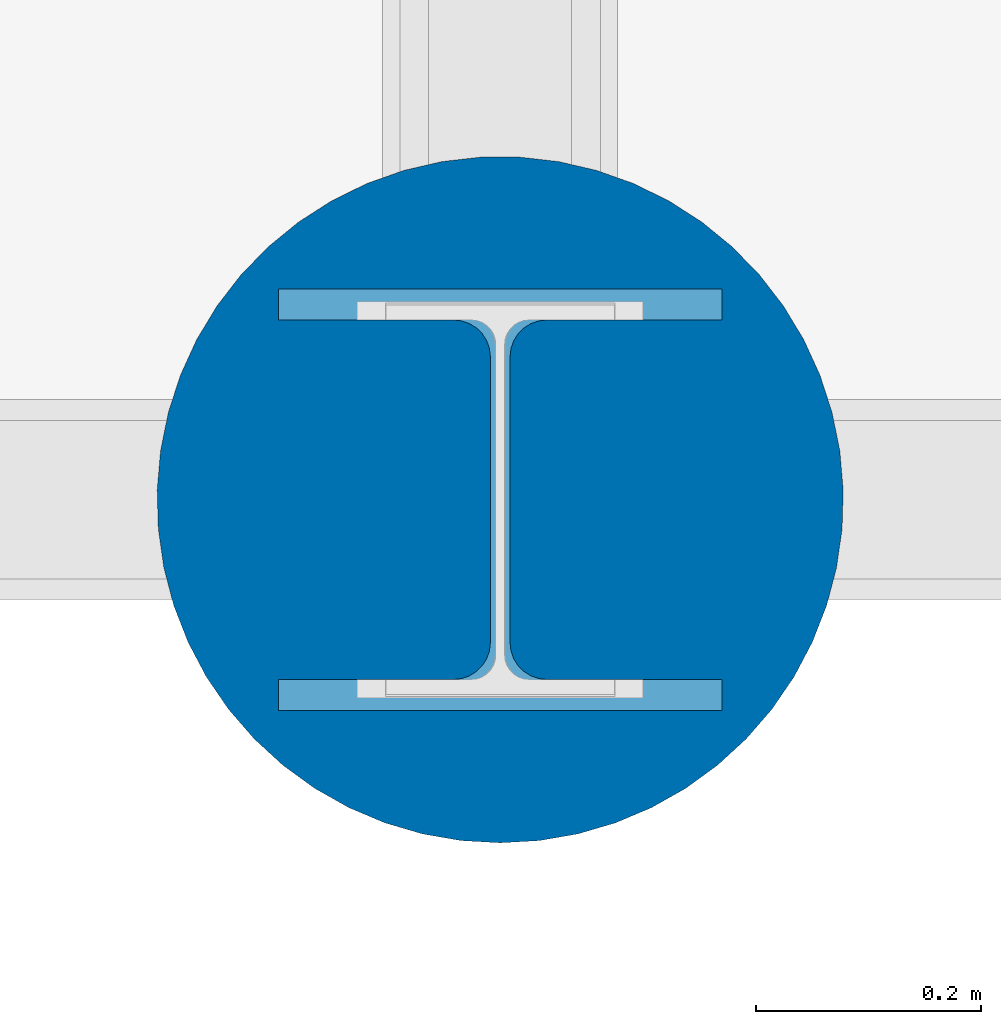
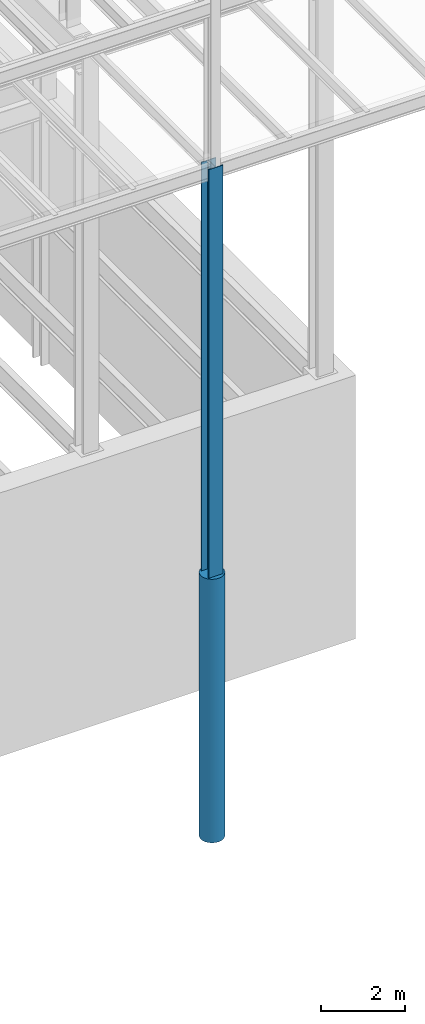
# One storey, part 81 of 150: 2 columns.
"""IFC2X3 building model written with IfcOpenShell, lengths in millimetres."""

from ifc_helpers import new_model, si_unit, frame, origin_with_axes, origin_2d_with_axis, place, context, subcontext, project, spatial, circle, i_section, extrude, material, type_object, element, save


model = new_model("IFC2X3")

# Units and contexts
model_context = context("Model", 3, precision=1e-05, world=origin_with_axes())
body_context = subcontext(model_context, "Body", "Model", "MODEL_VIEW")
ifc_project = project(units=[si_unit("LENGTHUNIT", "METRE", prefix="MILLI"), si_unit("AREAUNIT", "SQUARE_METRE"), si_unit("VOLUMEUNIT", "CUBIC_METRE"), si_unit("MASSUNIT", "GRAM", prefix="KILO"), si_unit("TIMEUNIT", "SECOND"), si_unit("PLANEANGLEUNIT", "RADIAN"), si_unit("SOLIDANGLEUNIT", "STERADIAN"), si_unit("THERMODYNAMICTEMPERATUREUNIT", "DEGREE_CELSIUS"), si_unit("LUMINOUSINTENSITYUNIT", "LUMEN")], contexts=[model_context])

# Site, building, storey
site_placement = place(None, origin_with_axes())
site = spatial("IfcSite", under=ifc_project, at=site_placement, CompositionType="ELEMENT")
building_placement = place(site_placement, origin_with_axes())
building = spatial("IfcBuilding", under=site, at=building_placement, Name="Undefined", CompositionType="ELEMENT")
storey_placement = place(building_placement, origin_with_axes())
storey = spatial("IfcBuildingStorey", under=building, at=storey_placement, Name="Undefined", CompositionType="ELEMENT", Elevation=0.0)

# Columns
ifc_material_1 = material(Name="STEEL/A992")
column_type_1 = type_object("IfcColumnType", Name="W14X145", PredefinedType="NOTDEFINED")
column_1_placement = place(storey_placement, frame((82194.4, 3454.4, 23774.39811024), z_axis=(0.0, 0.0, 1.0), x_axis=(1.0, 0.0, 0.0)))
element("IfcColumn", 1, at=column_1_placement, inside=storey, type_object=column_type_1, material=ifc_material_1, Name="COLUMN", ObjectType="W14X145", context=body_context, shape_type="SweptSolid", body=[
    extrude(i_section(OverallWidth=393.7, OverallDepth=374.65, WebThickness=17.4625, FlangeThickness=27.686, FilletRadius=32.6389, at=origin_2d_with_axis()), frame((0.0, 0.0, 11811.0), z_axis=(0.0, 0.0, -1.0), x_axis=(-1.0, 0.0, 0.0)), (0.0, 0.0, 1.0), 11811.0),
])
ifc_material_2 = material(Name="CONCRETE/5000")
column_type_2 = type_object("IfcColumnType", PredefinedType="NOTDEFINED")
column_2_placement = place(storey_placement, frame((82194.4, 3454.40000000001, 16154.4), z_axis=(0.0, 0.0, 1.0), x_axis=(1.0, 0.0, 0.0)))
element("IfcColumn", 2, at=column_2_placement, inside=storey, type_object=column_type_2, material=ifc_material_2, Name="COLUMN", context=body_context, shape_type="SweptSolid", body=[
    extrude(circle(Radius=304.8, at=origin_2d_with_axis()), frame((0.0, 0.0, 7620.0), z_axis=(0.0, 0.0, -1.0), x_axis=(0.0, -1.0, 0.0)), (0.0, 0.0, 1.0), 7619.99999999999),
])

save(model, "model.ifc")
